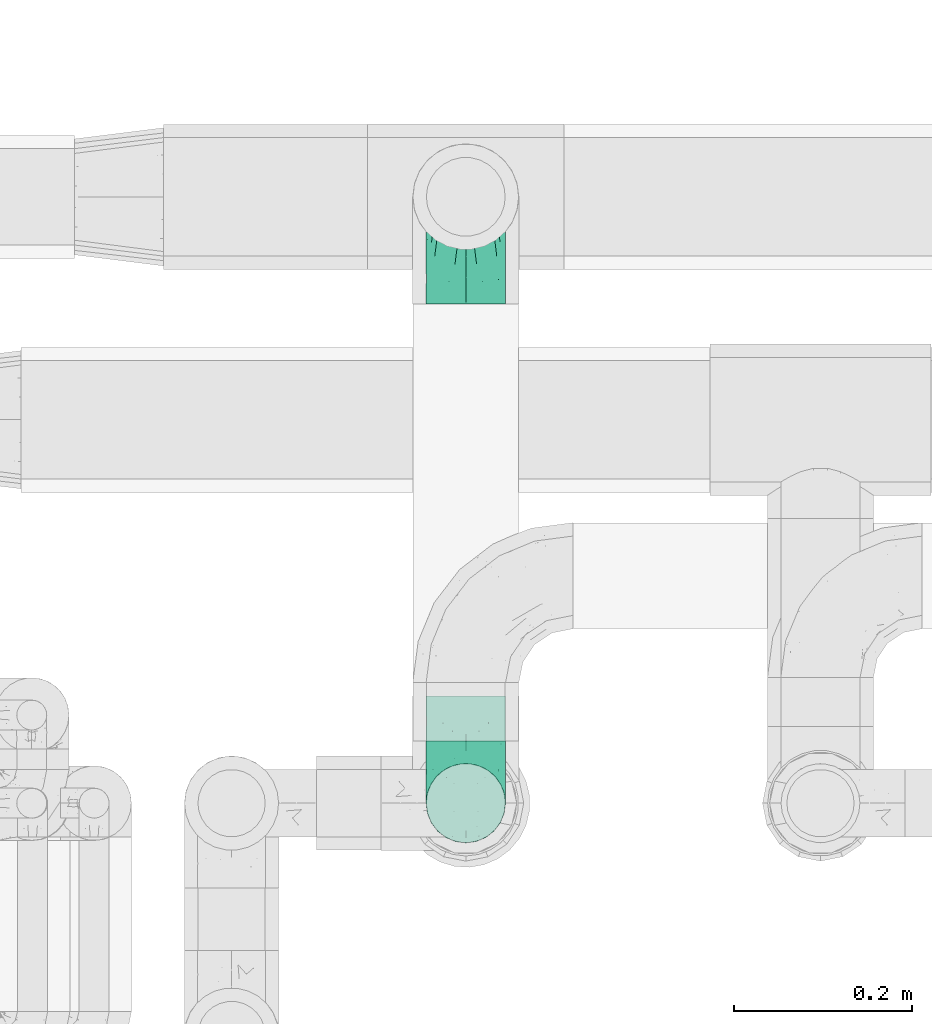
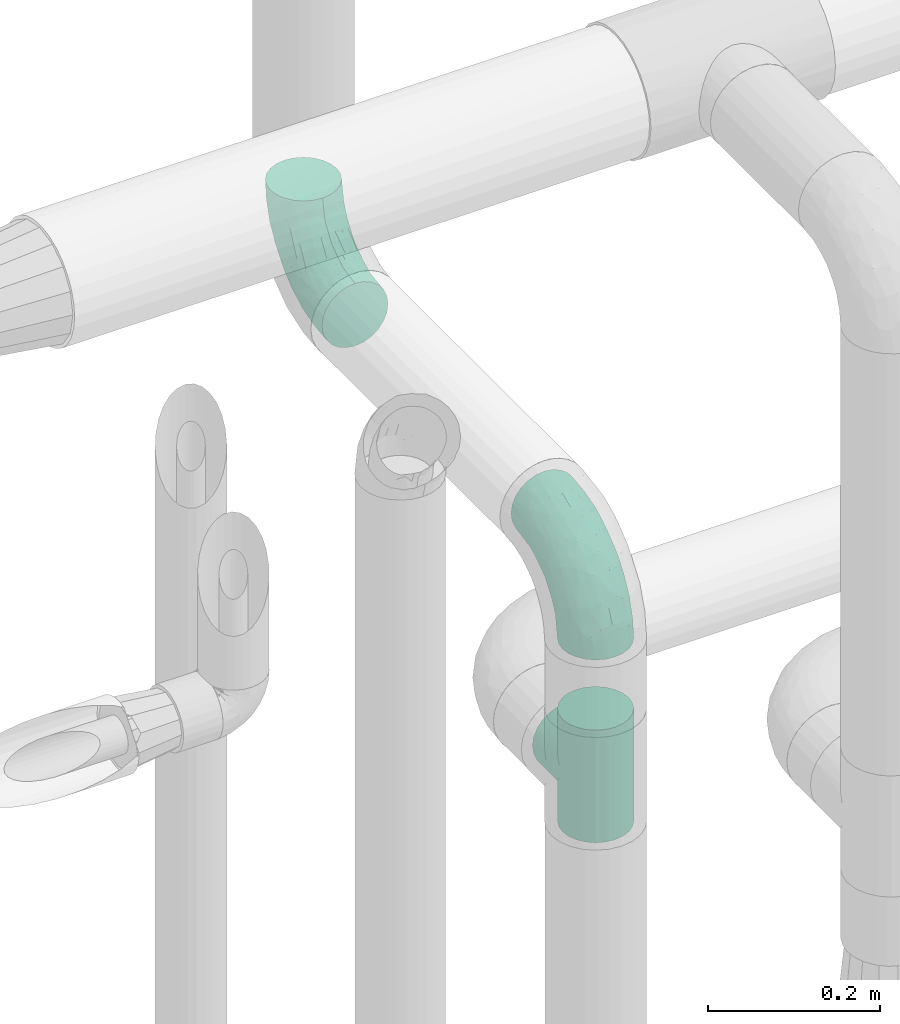
# One storey, part 705 of 827: 3 flow fittings.
"""IFC2X3 building model written with IfcOpenShell, lengths in millimetres."""

from ifc_helpers import new_model, entity, si_unit, converted_unit, derived_unit, direction, frame, origin, place, context, subcontext, project, spatial, faceted_brep, source, transform, mapped, material, type_object, type_shapes, element, save


model = new_model("IFC2X3")

# Units and contexts
model_context = context("Model", 3, precision=0.01, world=origin(), true_north=direction((6.12303176911189e-17, 1.0)))
body_context = subcontext(model_context, "Body", "Model", "MODEL_VIEW")
ifc_project = project(units=[si_unit("LENGTHUNIT", "METRE", prefix="MILLI"), si_unit("AREAUNIT", "SQUARE_METRE"), si_unit("VOLUMEUNIT", "CUBIC_METRE"), converted_unit("PLANEANGLEUNIT", "DEGREE", entity("IfcRatioMeasure", 0.0174532925199433), si_unit("PLANEANGLEUNIT", "RADIAN"), dimensions=[0, 0, 0, 0, 0, 0, 0]), si_unit("MASSUNIT", "GRAM", prefix="KILO"), derived_unit("MASSDENSITYUNIT", [(si_unit("MASSUNIT", "GRAM", prefix="KILO"), 1), (si_unit("LENGTHUNIT", "METRE"), -3)]), derived_unit("MOMENTOFINERTIAUNIT", [(si_unit("LENGTHUNIT", "METRE"), 4)]), si_unit("TIMEUNIT", "SECOND"), si_unit("FREQUENCYUNIT", "HERTZ"), si_unit("THERMODYNAMICTEMPERATUREUNIT", "DEGREE_CELSIUS"), derived_unit("THERMALTRANSMITTANCEUNIT", [(si_unit("MASSUNIT", "GRAM", prefix="KILO"), 1), (si_unit("THERMODYNAMICTEMPERATUREUNIT", "KELVIN"), -1), (si_unit("TIMEUNIT", "SECOND"), -3)]), derived_unit("VOLUMETRICFLOWRATEUNIT", [(si_unit("LENGTHUNIT", "METRE"), 3), (si_unit("TIMEUNIT", "SECOND"), -1)]), derived_unit("MASSFLOWRATEUNIT", [(si_unit("MASSUNIT", "GRAM", prefix="KILO"), 1), (si_unit("TIMEUNIT", "SECOND"), -1)]), derived_unit("ROTATIONALFREQUENCYUNIT", [(si_unit("TIMEUNIT", "SECOND"), -1)]), si_unit("ELECTRICCURRENTUNIT", "AMPERE"), si_unit("ELECTRICVOLTAGEUNIT", "VOLT"), si_unit("POWERUNIT", "WATT"), si_unit("FORCEUNIT", "NEWTON", prefix="KILO"), si_unit("ILLUMINANCEUNIT", "LUX"), si_unit("LUMINOUSFLUXUNIT", "LUMEN"), si_unit("LUMINOUSINTENSITYUNIT", "CANDELA"), derived_unit("USERDEFINED", [(si_unit("MASSUNIT", "GRAM", prefix="KILO"), -1), (si_unit("LENGTHUNIT", "METRE"), -2), (si_unit("TIMEUNIT", "SECOND"), 3), (si_unit("LUMINOUSFLUXUNIT", "LUMEN"), 1)]), derived_unit("LINEARVELOCITYUNIT", [(si_unit("LENGTHUNIT", "METRE"), 1), (si_unit("TIMEUNIT", "SECOND"), -1)]), si_unit("PRESSUREUNIT", "PASCAL"), derived_unit("USERDEFINED", [(si_unit("LENGTHUNIT", "METRE"), -2), (si_unit("MASSUNIT", "GRAM", prefix="KILO"), 1), (si_unit("TIMEUNIT", "SECOND"), -2)]), derived_unit("LINEARFORCEUNIT", [(si_unit("MASSUNIT", "GRAM", prefix="KILO"), 1), (si_unit("LENGTHUNIT", "METRE"), 1), (si_unit("TIMEUNIT", "SECOND"), -2), (si_unit("LENGTHUNIT", "METRE"), -1)]), derived_unit("PLANARFORCEUNIT", [(si_unit("MASSUNIT", "GRAM", prefix="KILO"), 1), (si_unit("LENGTHUNIT", "METRE"), 1), (si_unit("TIMEUNIT", "SECOND"), -2), (si_unit("LENGTHUNIT", "METRE"), -2)])], contexts=[model_context])

# Site, building, storey
site_placement = place(None, origin())
site = spatial("IfcSite", under=ifc_project, at=site_placement, CompositionType="ELEMENT")
building_placement = place(site_placement, origin())
building = spatial("IfcBuilding", under=site, at=building_placement, CompositionType="ELEMENT")
storey_placement = place(building_placement, frame((0.0, 0.0, 28200.0)))
storey = spatial("IfcBuildingStorey", under=building, at=storey_placement, Name="08", CompositionType="ELEMENT", Elevation=28200.0)

# Flow fittings
ifc_material = material()
pipe_fitting_type_1 = type_object("IfcPipeFittingType", Name="ADSK_2", PredefinedType="NOTDEFINED", material=ifc_material)
shared_shape_1 = source(origin(), body_context, "Body", "Brep", [
    faceted_brep([(-120.0, 22.25, -38.54), (-120.0, 11.52, -42.98), (-120.0, 0.0, -44.5), (-120.0, -11.52, -42.98), (-120.0, -22.25, -38.54), (-120.0, -31.47, -31.47), (-120.0, -38.54, -22.25), (-120.0, -42.98, -11.52), (-120.0, -44.5, 0.0), (-120.0, -42.98, 11.52), (-120.0, -38.54, 22.25), (-120.0, -31.47, 31.47), (-120.0, -22.25, 38.54), (-120.0, -11.52, 42.98), (-120.0, 0.0, 44.5), (-120.0, 11.52, 42.98), (-120.0, 22.25, 38.54), (-120.0, 31.47, 31.47), (-120.0, 38.54, 22.25), (-120.0, 42.98, 11.52), (-120.0, 44.5, 0.0), (-120.0, 42.98, -11.52), (-120.0, 38.54, -22.25), (-120.0, 31.47, -31.47), (0.0, 120.0, -44.5), (-11.52, 120.0, -42.98), (-22.25, 120.0, -38.54), (-31.47, 120.0, -31.47), (-38.54, 120.0, -22.25), (-42.98, 120.0, -11.52), (-44.5, 120.0, 0.0), (-42.98, 120.0, 11.52), (-38.54, 120.0, 22.25), (-31.47, 120.0, 31.47), (-22.25, 120.0, 38.54), (-11.52, 120.0, 42.98), (0.0, 120.0, 44.5), (11.52, 120.0, 42.98), (22.25, 120.0, 38.54), (31.47, 120.0, 31.47), (38.54, 120.0, 22.25), (42.98, 120.0, 11.52), (44.5, 120.0, 0.0), (42.98, 120.0, -11.52), (38.54, 120.0, -22.25), (31.47, 120.0, -31.47), (22.25, 120.0, -38.54), (11.52, 120.0, -42.98), (-20.51, 85.66, 41.98), (-29.31, 93.55, 36.45), (-98.0, -41.6, 0.0), (-80.92, -37.22, 14.68), (-66.68, -9.63, 39.67), (-84.59, -24.55, 33.9), (-50.35, -12.87, 32.85), (-77.42, -38.89, 0.0), (-22.01, -9.62, 13.21), (-37.75, -22.46, 0.0), (-20.72, -9.39, 0.0), (-89.18, -33.47, 25.4), (12.87, 50.35, 32.85), (24.55, 84.59, 33.9), (9.63, 66.68, 39.67), (-49.55, -27.06, 11.21), (-28.67, -9.99, 21.67), (-52.01, -22.41, 23.47), (-95.53, -16.28, 40.49), (-86.01, -3.42, 43.77), (22.41, 52.01, 23.47), (9.05, 21.37, 13.44), (26.5, 49.37, 12.73), (33.47, 89.18, 25.4), (37.22, 80.92, 14.68), (16.28, 95.53, 40.49), (3.42, 86.01, 43.77), (-7.84, 52.6, 43.16), (-84.39, 31.88, 36.84), (-30.52, 34.28, 44.33), (-21.99, 28.55, 42.22), (-93.56, 38.23, 28.63), (-65.04, 31.74, 41.51), (-91.98, 19.0, 41.83), (-34.03, 70.24, 39.41), (-96.36, 44.0, 18.64), (-98.49, 46.74, 8.65), (-76.5, 56.97, 9.76), (-4.96, 4.47, 11.32), (-7.16, 6.18, 18.93), (-56.62, 75.93, 12.18), (-66.61, 66.61, 0.0), (-92.12, 7.25, 44.33), (-7.23, 92.66, 44.32), (30.68, 57.59, 0.0), (-44.45, 94.8, 18.75), (-36.39, 101.98, 28.14), (-46.83, 97.45, 9.69), (-38.03, 47.61, 43.21), (-24.7, 65.7, 43.29), (41.6, 98.0, 0.0), (-54.11, 72.8, 21.53), (-47.95, 9.75, 42.93), (-18.65, 18.65, 37.89), (-91.11, 50.25, 0.0), (-50.25, 91.11, 0.0), (-57.59, -30.68, 0.0), (-44.16, 67.2, 34.92), (-55.15, 62.16, 29.74), (-68.1, 47.21, 32.31), (-51.09, 51.09, 38.36), (-16.69, 62.62, 44.46), (-58.26, 18.84, 44.48), (-71.55, 55.71, 20.49), (-43.13, 80.04, 29.45), (-37.23, 0.88, 36.78), (-18.15, 10.22, 33.09), (5.51, 28.08, 26.74), (-3.68, 3.68, 0.0), (9.39, 20.72, 0.0), (-2.58, 27.98, 33.59), (-2.38, 41.22, 38.93), (-16.09, 4.55, 27.06), (38.89, 77.42, 0.0), (22.46, 37.75, 0.0), (-92.66, 7.23, -44.32), (-22.01, -9.62, -13.21), (-49.81, -26.66, -12.91), (-28.67, -9.99, -21.67), (-62.62, 16.69, -44.46), (-65.04, 31.74, -41.51), (-38.89, 47.26, -43.11), (-56.62, 75.93, -12.18), (-93.56, 38.23, -28.63), (-84.39, 31.88, -36.84), (16.28, 95.53, -40.49), (3.42, 86.01, -43.77), (-98.49, 46.74, -8.65), (-44.45, 94.8, -18.75), (-54.11, 72.8, -21.53), (-76.5, 56.97, -9.76), (24.55, 84.59, -33.9), (9.63, 66.68, -39.67), (-96.36, 44.0, -18.64), (-29.4, 93.16, -36.47), (-91.98, 19.0, -41.83), (-80.92, -37.22, -14.68), (-52.6, 7.84, -43.16), (-86.01, -3.42, -43.77), (-89.18, -33.47, -25.4), (-52.01, -22.41, -23.47), (-50.35, -12.87, -32.85), (-84.59, -24.55, -33.9), (-66.68, -9.63, -39.67), (-95.53, -16.28, -40.49), (-68.1, 47.21, -32.31), (-35.81, 11.1, -40.85), (-19.61, 28.53, -41.59), (-18.65, 18.65, -37.89), (-4.97, 4.47, -11.34), (9.05, 21.37, -13.44), (-34.28, 30.52, -44.33), (-9.75, 47.95, -42.93), (-2.58, 27.98, -33.59), (-18.15, 10.22, -33.09), (-46.83, 97.45, -9.69), (12.87, 50.35, -32.85), (26.8, 49.13, -11.4), (-7.34, 92.03, -44.33), (-21.02, 83.86, -42.03), (-44.6, 66.82, -34.8), (-55.46, 62.18, -29.47), (37.22, 80.92, -14.68), (33.47, 89.18, -25.4), (-34.39, 70.11, -39.28), (-25.04, 64.41, -43.37), (-18.84, 58.26, -44.48), (22.41, 52.01, -23.47), (-36.39, 101.98, -28.14), (-51.09, 51.09, -38.36), (-43.13, 80.04, -29.45), (-71.55, 55.71, -20.49), (-7.15, 6.2, -18.94), (5.51, 28.08, -26.74), (-37.23, 0.88, -36.78), (-2.38, 41.22, -38.93), (-16.09, 4.55, -27.06)], [[[0, 1, 2, 3, 4, 5, 6, 7, 8, 9, 10, 11, 12, 13, 14, 15, 16, 17, 18, 19, 20, 21, 22, 23]], [[24, 25, 26, 27, 28, 29, 30, 31, 32, 33, 34, 35, 36, 37, 38, 39, 40, 41, 42, 43, 44, 45, 46, 47]], [[48, 34, 49]], [[50, 51, 9]], [[52, 53, 54]], [[9, 51, 10]], [[55, 51, 50]], [[56, 57, 58]], [[51, 59, 10]], [[60, 61, 62]], [[63, 64, 65]], [[13, 12, 66]], [[67, 14, 13]], [[68, 69, 70]], [[71, 68, 72]], [[38, 73, 61]], [[74, 75, 62]], [[17, 16, 76]], [[77, 78, 75]], [[79, 18, 17]], [[80, 76, 81]], [[35, 34, 48]], [[49, 82, 48]], [[18, 83, 19]], [[16, 81, 76]], [[20, 19, 84]], [[85, 84, 83]], [[56, 86, 87]], [[85, 88, 89]], [[37, 36, 74]], [[90, 14, 67]], [[79, 17, 76]], [[63, 65, 51]], [[13, 66, 67]], [[61, 39, 38]], [[91, 74, 36]], [[70, 92, 72]], [[93, 94, 32]], [[95, 88, 93]], [[62, 73, 74]], [[82, 96, 97]], [[40, 72, 41]], [[72, 68, 70]], [[71, 72, 40]], [[34, 33, 49]], [[72, 98, 41]], [[99, 93, 88]], [[71, 39, 61]], [[78, 100, 101]], [[85, 89, 102]], [[53, 52, 66]], [[103, 95, 30]], [[12, 11, 53]], [[103, 89, 88]], [[104, 57, 63]], [[91, 48, 97]], [[93, 32, 31]], [[33, 32, 94]], [[16, 15, 81]], [[105, 106, 107]], [[76, 107, 79]], [[35, 91, 36]], [[80, 96, 108]], [[31, 95, 93]], [[65, 53, 59]], [[73, 38, 37]], [[75, 74, 109]], [[61, 60, 68]], [[11, 10, 59]], [[54, 53, 65]], [[100, 67, 52]], [[110, 81, 90]], [[15, 14, 90]], [[76, 80, 108]], [[107, 76, 108]], [[83, 79, 111]], [[94, 49, 33]], [[82, 105, 108]], [[84, 85, 102]], [[111, 88, 85]], [[99, 88, 111]], [[94, 93, 112]], [[48, 91, 35]], [[74, 91, 109]], [[69, 87, 86]], [[113, 54, 114]], [[64, 56, 87]], [[60, 115, 68]], [[116, 117, 86]], [[69, 68, 115]], [[79, 83, 18]], [[85, 83, 111]], [[81, 110, 80]], [[110, 77, 96]], [[110, 96, 80]], [[97, 96, 109]], [[107, 108, 105]], [[111, 79, 107]], [[77, 75, 109]], [[118, 119, 101]], [[96, 77, 109]], [[77, 110, 100]], [[67, 100, 110]], [[100, 52, 113]], [[60, 119, 118]], [[118, 120, 115]], [[64, 54, 65]], [[114, 120, 118]], [[118, 115, 60]], [[115, 120, 87]], [[74, 73, 37]], [[61, 73, 62]], [[53, 66, 12]], [[67, 66, 52]], [[110, 90, 67]], [[15, 90, 81]], [[105, 49, 112]], [[96, 82, 108]], [[119, 60, 62]], [[118, 101, 114]], [[62, 75, 119]], [[78, 119, 75]], [[49, 105, 82]], [[105, 112, 106]], [[99, 112, 93]], [[111, 107, 106]], [[113, 114, 101]], [[54, 120, 114]], [[100, 113, 101]], [[52, 54, 113]], [[20, 84, 102]], [[83, 84, 19]], [[111, 106, 99]], [[112, 99, 106]], [[100, 78, 77]], [[119, 78, 101]], [[39, 71, 40]], [[68, 71, 61]], [[65, 59, 51]], [[11, 59, 53]], [[30, 95, 31]], [[103, 88, 95]], [[9, 8, 50]], [[98, 72, 121]], [[98, 42, 41]], [[49, 94, 112]], [[56, 63, 57]], [[51, 55, 104]], [[92, 121, 72]], [[86, 58, 116]], [[54, 64, 120]], [[115, 87, 69]], [[120, 64, 87]], [[58, 86, 56]], [[86, 117, 69]], [[91, 97, 109]], [[122, 69, 117]], [[82, 97, 48]], [[63, 56, 64]], [[104, 63, 51]], [[69, 122, 70]], [[92, 70, 122]], [[123, 2, 1]], [[124, 125, 126]], [[127, 128, 129]], [[103, 130, 89]], [[23, 131, 132]], [[47, 133, 134]], [[102, 135, 20]], [[130, 136, 137]], [[102, 138, 135]], [[139, 140, 133]], [[22, 21, 141]], [[27, 26, 142]], [[46, 45, 139]], [[0, 143, 1]], [[6, 144, 7]], [[145, 146, 127]], [[144, 50, 7]], [[147, 148, 144]], [[144, 6, 147]], [[149, 150, 151]], [[4, 3, 152]], [[23, 22, 131]], [[132, 131, 153]], [[43, 42, 98]], [[125, 104, 144]], [[154, 155, 156]], [[146, 151, 152]], [[4, 150, 5]], [[123, 146, 2]], [[157, 158, 117]], [[130, 138, 89]], [[29, 28, 136]], [[159, 160, 155]], [[161, 162, 156]], [[89, 138, 102]], [[163, 30, 29]], [[164, 140, 139]], [[163, 136, 130]], [[23, 132, 0]], [[158, 165, 122]], [[25, 24, 166]], [[0, 132, 143]], [[4, 152, 150]], [[142, 26, 167]], [[3, 2, 146]], [[167, 26, 25]], [[133, 47, 46]], [[168, 153, 169]], [[146, 145, 151]], [[149, 126, 148]], [[44, 170, 171]], [[24, 47, 134]], [[170, 44, 43]], [[144, 148, 125]], [[170, 98, 121]], [[168, 142, 172]], [[129, 173, 174]], [[98, 170, 43]], [[147, 5, 150]], [[157, 58, 124]], [[92, 122, 165]], [[134, 166, 24]], [[175, 139, 171]], [[28, 27, 176]], [[29, 136, 163]], [[132, 128, 143]], [[45, 44, 171]], [[164, 139, 175]], [[160, 134, 140]], [[174, 173, 166]], [[141, 131, 22]], [[132, 153, 177]], [[128, 132, 177]], [[123, 143, 127]], [[172, 142, 167]], [[176, 142, 178]], [[130, 179, 138]], [[138, 179, 141]], [[176, 136, 28]], [[130, 137, 179]], [[174, 166, 134]], [[167, 25, 166]], [[143, 123, 1]], [[146, 123, 127]], [[150, 149, 148]], [[157, 124, 180]], [[181, 161, 164]], [[181, 158, 180]], [[124, 126, 180]], [[170, 165, 175]], [[141, 21, 135]], [[131, 141, 179]], [[131, 179, 153]], [[179, 137, 169]], [[129, 128, 177]], [[127, 143, 128]], [[129, 177, 172]], [[129, 174, 159]], [[159, 145, 127]], [[182, 154, 156]], [[129, 159, 127]], [[159, 174, 160]], [[134, 160, 174]], [[140, 164, 183]], [[162, 182, 156]], [[126, 149, 184]], [[181, 164, 175]], [[164, 161, 183]], [[158, 181, 175]], [[184, 162, 161]], [[146, 152, 3]], [[150, 152, 151]], [[139, 133, 46]], [[134, 133, 140]], [[184, 161, 181]], [[161, 156, 183]], [[155, 183, 156]], [[160, 140, 183]], [[184, 149, 162]], [[182, 162, 149]], [[149, 151, 182]], [[154, 151, 145]], [[151, 154, 182]], [[159, 154, 145]], [[159, 155, 154]], [[183, 155, 160]], [[141, 135, 138]], [[20, 135, 21]], [[136, 178, 137]], [[169, 178, 168]], [[172, 167, 173]], [[168, 172, 177]], [[153, 168, 177]], [[142, 168, 178]], [[179, 169, 153]], [[137, 178, 169]], [[5, 147, 6]], [[148, 147, 150]], [[175, 171, 170]], [[45, 171, 139]], [[130, 103, 163]], [[30, 163, 103]], [[50, 144, 55]], [[50, 8, 7]], [[142, 176, 27]], [[136, 176, 178]], [[126, 125, 148]], [[104, 55, 144]], [[170, 121, 92]], [[58, 57, 124]], [[180, 126, 184]], [[181, 180, 184]], [[180, 158, 157]], [[158, 122, 117]], [[58, 157, 116]], [[172, 173, 129]], [[116, 157, 117]], [[166, 173, 167]], [[124, 57, 125]], [[104, 125, 57]], [[175, 165, 158]], [[92, 165, 170]]]),
])
type_shapes(pipe_fitting_type_1, [shared_shape_1])
for number, where, z_axis, x_axis, name in (
    (1, (57050.07, 18180.1, 2599.74), (-1.0, 0.0, 0.0), (0.0, 0.0, -1.0), "ADSK_2"),
    (2, (57050.07, 17500.0, 2599.74), (1.0, 0.0, 0.0), (0.0, -1.0, 0.0), "ADSK_2"),
):
    element("IfcFlowFitting", number, at=place(storey_placement, frame(where, z_axis=z_axis, x_axis=x_axis)), inside=storey, type_object=pipe_fitting_type_1, material=ifc_material, Name=name, ObjectType="ADSK_2", context=body_context, shape_type="MappedRepresentation", body=[
        mapped(shared_shape_1, transform((0.0, 0.0, 0.0), scale=1.0)),
    ])
pipe_fitting_type_2 = type_object("IfcPipeFittingType", Name="ADSK_2", PredefinedType="NOTDEFINED", material=ifc_material)
shared_shape_2 = source(origin(), body_context, "Body", "Brep", [
    faceted_brep([(-80.0, 22.25, -38.54), (-80.0, 11.52, -42.98), (-80.0, 0.0, -44.5), (-80.0, -11.52, -42.98), (-80.0, -22.25, -38.54), (-80.0, -26.86, -35.0), (-80.0, -31.47, -31.47), (-80.0, -35.0, -26.86), (-80.0, -38.54, -22.25), (-80.0, -40.76, -16.88), (-80.0, -42.98, -11.52), (-80.0, -44.5, 0.0), (-80.0, -42.98, 11.52), (-80.0, -40.76, 16.88), (-80.0, -38.54, 22.25), (-80.0, -35.0, 26.86), (-80.0, -31.47, 31.47), (-80.0, -26.86, 35.0), (-80.0, -22.25, 38.54), (-80.0, -11.52, 42.98), (-80.0, 0.0, 44.5), (-80.0, 11.52, 42.98), (-80.0, 22.25, 38.54), (-80.0, 31.47, 31.47), (-80.0, 38.54, 22.25), (-80.0, 42.98, 11.52), (-80.0, 44.5, 0.0), (-80.0, 42.98, -11.52), (-80.0, 38.54, -22.25), (-80.0, 31.47, -31.47), (80.0, 0.0, -44.5), (80.0, 11.52, -42.98), (80.0, 22.25, -38.54), (80.0, 31.47, -31.47), (80.0, 38.54, -22.25), (80.0, 42.98, -11.52), (80.0, 44.5, 0.0), (80.0, 42.98, 11.52), (80.0, 38.54, 22.25), (80.0, 31.47, 31.47), (80.0, 22.25, 38.54), (80.0, 11.52, 42.98), (80.0, 0.0, 44.5), (80.0, -11.52, 42.98), (80.0, -22.25, 38.54), (80.0, -26.86, 35.0), (80.0, -31.47, 31.47), (80.0, -35.0, 26.86), (80.0, -38.54, 22.25), (80.0, -40.76, 16.88), (80.0, -42.98, 11.52), (80.0, -44.5, 0.0), (80.0, -42.98, -11.52), (80.0, -40.76, -16.88), (80.0, -38.54, -22.25), (80.0, -35.0, -26.86), (80.0, -31.47, -31.47), (80.0, -26.86, -35.0), (80.0, -22.25, -38.54), (80.0, -11.52, -42.98), (43.26, -43.26, 10.45), (44.5, -44.5, 0.0), (-43.26, -43.26, 10.45), (-44.5, -44.5, 0.0), (41.54, -41.54, 15.16), (39.82, -39.82, 19.87), (22.0, -22.0, 38.68), (34.79, -34.79, 27.75), (28.72, -28.72, 33.99), (-41.54, -41.54, 15.16), (37.3, -37.3, 23.81), (-39.82, -39.82, 19.87), (-22.0, -22.0, 38.68), (-34.79, -34.79, 27.75), (-28.72, -28.72, 33.99), (-37.3, -37.3, 23.81), (-14.86, -14.86, 41.95), (7.48, -7.48, 43.87), (14.86, -14.86, 41.95), (0.0, 0.0, 44.5), (-7.48, -7.48, 43.87), (7.48, -7.48, -43.87), (0.0, 0.0, -44.5), (14.86, -14.86, -41.95), (-28.72, -28.72, -33.99), (-7.48, -7.48, -43.87), (-41.54, -41.54, -15.16), (-43.26, -43.26, -10.45), (-37.3, -37.3, -23.81), (-34.79, -34.79, -27.75), (-14.86, -14.86, -41.95), (22.0, -22.0, -38.68), (28.72, -28.72, -33.99), (39.82, -39.82, -19.87), (37.3, -37.3, -23.81), (34.79, -34.79, -27.75), (-39.82, -39.82, -19.87), (43.26, -43.26, -10.45), (41.54, -41.54, -15.16), (-22.0, -22.0, -38.68), (38.54, -70.0, -22.25), (42.98, -70.0, -11.52), (44.5, -70.0, 0.0), (42.98, -70.0, 11.52), (38.54, -70.0, 22.25), (31.47, -70.0, 31.47), (22.25, -70.0, 38.54), (11.52, -70.0, 42.98), (0.0, -70.0, 44.5), (-11.52, -70.0, 42.98), (-22.25, -70.0, 38.54), (-31.47, -70.0, 31.47), (-38.54, -70.0, 22.25), (-42.98, -70.0, 11.52), (-44.5, -70.0, 0.0), (-42.98, -70.0, -11.52), (-38.54, -70.0, -22.25), (-31.47, -70.0, -31.47), (-22.25, -70.0, -38.54), (-11.52, -70.0, -42.98), (0.0, -70.0, -44.5), (11.52, -70.0, -42.98), (22.25, -70.0, -38.54), (31.47, -70.0, -31.47)], [[[0, 1, 2, 3, 4, 5, 6, 7, 8, 9, 10, 11, 12, 13, 14, 15, 16, 17, 18, 19, 20, 21, 22, 23, 24, 25, 26, 27, 28, 29]], [[30, 31, 32, 33, 34, 35, 36, 37, 38, 39, 40, 41, 42, 43, 44, 45, 46, 47, 48, 49, 50, 51, 52, 53, 54, 55, 56, 57, 58, 59]], [[51, 50, 60]], [[60, 61, 51]], [[62, 11, 63]], [[50, 49, 64]], [[49, 48, 65]], [[44, 66, 45]], [[46, 67, 47]], [[67, 46, 68]], [[12, 69, 13]], [[48, 70, 65]], [[50, 64, 60]], [[68, 46, 45]], [[71, 13, 69]], [[11, 62, 12]], [[12, 62, 69]], [[49, 65, 64]], [[72, 18, 17]], [[73, 74, 16]], [[15, 14, 75]], [[16, 74, 17]], [[72, 76, 18]], [[15, 75, 73]], [[70, 47, 67]], [[45, 66, 68]], [[43, 42, 77]], [[14, 71, 75]], [[66, 44, 78]], [[77, 78, 43]], [[73, 16, 15]], [[77, 42, 79]], [[80, 79, 20]], [[78, 44, 43]], [[24, 23, 39, 38]], [[25, 24, 38, 37]], [[22, 21, 41, 40]], [[23, 22, 40, 39]], [[41, 21, 20, 79, 42]], [[26, 25, 37, 36]], [[71, 14, 13]], [[80, 19, 76]], [[19, 80, 20]], [[19, 18, 76]], [[72, 17, 74]], [[47, 70, 48]], [[33, 29, 28, 34]], [[28, 27, 35, 34]], [[0, 29, 33, 32]], [[26, 36, 35, 27]], [[30, 59, 81]], [[31, 30, 82, 2, 1]], [[81, 59, 83]], [[84, 6, 5]], [[32, 31, 1, 0]], [[59, 58, 83]], [[30, 81, 82]], [[82, 85, 2]], [[10, 86, 87]], [[88, 7, 89]], [[85, 90, 3]], [[2, 85, 3]], [[90, 4, 3]], [[91, 57, 92]], [[57, 56, 92]], [[54, 93, 94]], [[91, 58, 57]], [[95, 92, 56]], [[9, 96, 86]], [[54, 94, 55]], [[58, 91, 83]], [[52, 97, 98]], [[97, 52, 51]], [[93, 53, 98]], [[61, 97, 51]], [[87, 63, 11]], [[94, 95, 55]], [[84, 5, 99]], [[7, 88, 8]], [[5, 4, 99]], [[6, 84, 89]], [[6, 89, 7]], [[93, 54, 53]], [[99, 4, 90]], [[52, 98, 53]], [[10, 9, 86]], [[96, 9, 8]], [[10, 87, 11]], [[96, 8, 88]], [[95, 56, 55]], [[100, 101, 102, 103, 104, 105, 106, 107, 108, 109, 110, 111, 112, 113, 114, 115, 116, 117, 118, 119, 120, 121, 122, 123]], [[62, 63, 114]], [[113, 62, 114]], [[111, 110, 74]], [[73, 112, 111]], [[71, 113, 112]], [[76, 110, 109]], [[113, 71, 69, 62]], [[74, 73, 111]], [[112, 73, 75, 71]], [[76, 72, 110]], [[108, 79, 80]], [[76, 109, 80]], [[74, 110, 72]], [[80, 109, 108]], [[77, 108, 107]], [[106, 78, 107]], [[104, 103, 65]], [[67, 105, 104]], [[68, 106, 105]], [[60, 103, 102]], [[68, 66, 106]], [[78, 77, 107]], [[66, 78, 106]], [[61, 60, 102]], [[104, 65, 70, 67]], [[103, 60, 64, 65]], [[68, 105, 67]], [[108, 77, 79]], [[61, 102, 97]], [[101, 97, 102]], [[95, 100, 123]], [[123, 122, 92]], [[93, 101, 100]], [[83, 122, 121]], [[101, 93, 98, 97]], [[92, 95, 123]], [[100, 95, 94, 93]], [[83, 91, 122]], [[120, 82, 81]], [[83, 121, 81]], [[92, 122, 91]], [[81, 121, 120]], [[85, 120, 119]], [[118, 90, 119]], [[116, 115, 96]], [[89, 117, 116]], [[84, 118, 117]], [[87, 115, 114]], [[84, 99, 118]], [[90, 85, 119]], [[99, 90, 118]], [[63, 87, 114]], [[116, 96, 88, 89]], [[115, 87, 86, 96]], [[84, 117, 89]], [[120, 85, 82]]]),
])
type_shapes(pipe_fitting_type_2, [shared_shape_2])
flow_fitting_placement = place(storey_placement, frame((57050.07, 17500.0, 2300.0), z_axis=(1.0, 0.0, 0.0), x_axis=(0.0, 0.0, 1.0)))
element("IfcFlowFitting", 3, at=flow_fitting_placement, inside=storey, type_object=pipe_fitting_type_2, material=ifc_material, Name="ADSK_2", ObjectType="ADSK_2", context=body_context, shape_type="MappedRepresentation", body=[
    mapped(shared_shape_2, transform((0.0, 0.0, 0.0), scale=1.0)),
])

save(model, "model.ifc")
